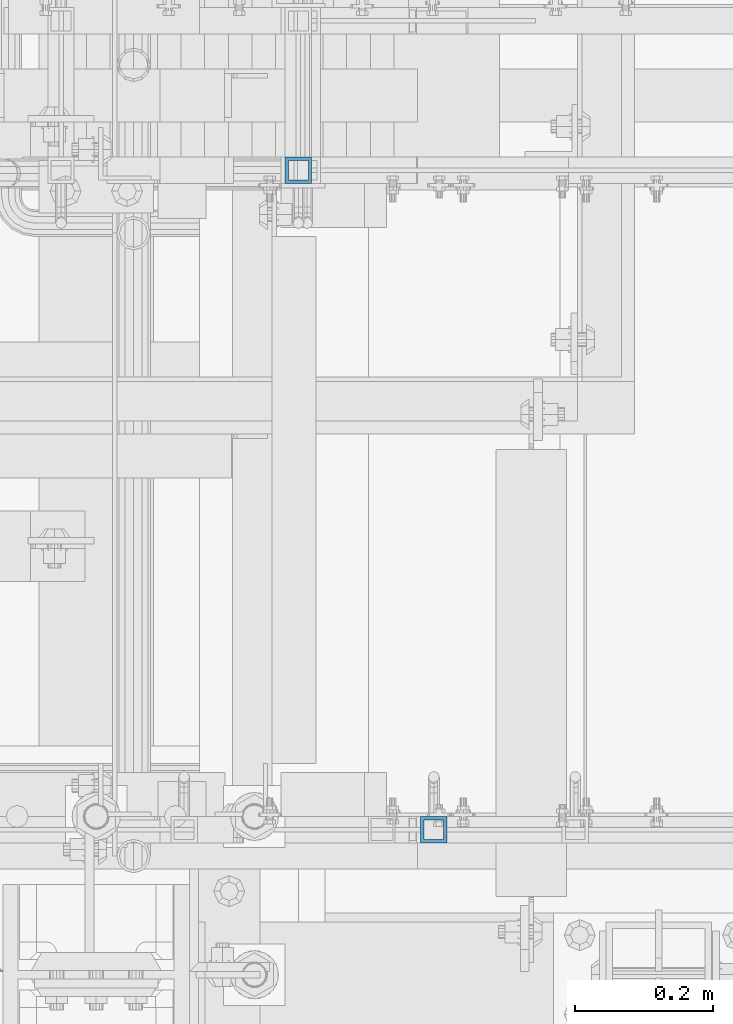
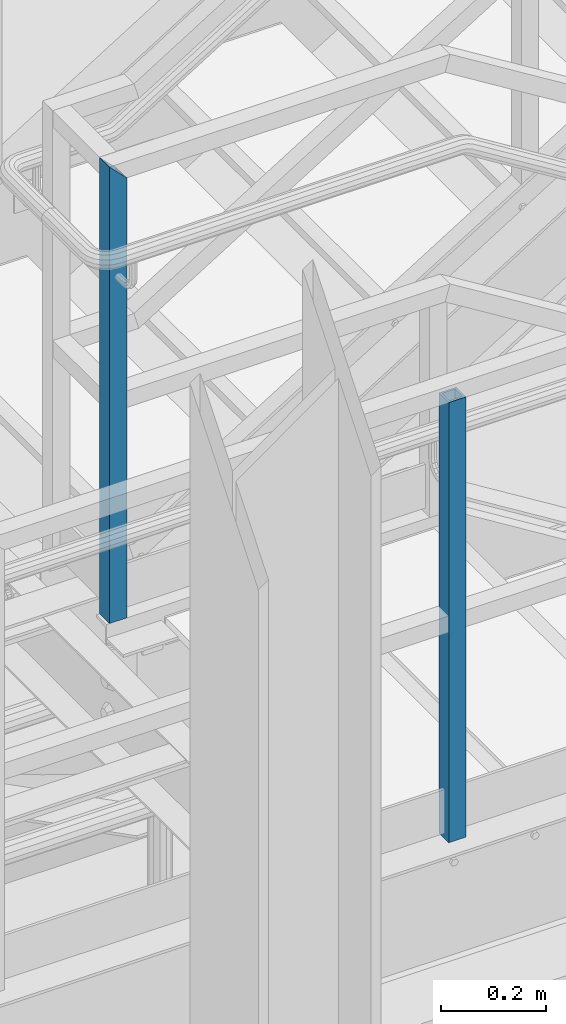
# One storey, part 574 of 1876: 2 columns, 2 elements without a shape of their own.
"""IFC2X3 building model written with IfcOpenShell, lengths in millimetres."""

from ifc_helpers import new_model, si_unit, frame, origin_with_axes, place, context, subcontext, project, spatial, faceted_brep, material, type_object, element, aggregate, save


model = new_model("IFC2X3")

# Units and contexts
model_context = context("Model", 3, precision=1e-05, world=origin_with_axes())
body_context = subcontext(model_context, "Body", "Model", "MODEL_VIEW")
ifc_project = project(units=[si_unit("LENGTHUNIT", "METRE", prefix="MILLI"), si_unit("AREAUNIT", "SQUARE_METRE"), si_unit("VOLUMEUNIT", "CUBIC_METRE"), si_unit("MASSUNIT", "GRAM", prefix="KILO"), si_unit("TIMEUNIT", "SECOND"), si_unit("PLANEANGLEUNIT", "RADIAN"), si_unit("SOLIDANGLEUNIT", "STERADIAN"), si_unit("THERMODYNAMICTEMPERATUREUNIT", "DEGREE_CELSIUS"), si_unit("LUMINOUSINTENSITYUNIT", "LUMEN")], contexts=[model_context])

# Site, building, storey
site_placement = place(None, origin_with_axes())
site = spatial("IfcSite", under=ifc_project, at=site_placement, CompositionType="ELEMENT")
building_placement = place(site_placement, origin_with_axes())
building = spatial("IfcBuilding", under=site, at=building_placement, Name="Undefined", CompositionType="ELEMENT")
storey_placement = place(building_placement, origin_with_axes())
storey = spatial("IfcBuildingStorey", under=building, at=storey_placement, Name="Undefined", CompositionType="ELEMENT", Elevation=0.0)

# Assembly, column
assembly_1_placement = place(storey_placement, origin_with_axes())
assembly_1 = element("IfcElementAssembly", 1, at=assembly_1_placement, inside=storey, Name="RAIL", AssemblyPlace="NOTDEFINED", PredefinedType="RIGID_FRAME")
ifc_material = material()
column_type = type_object("IfcColumnType", Name="HSS1-1/2X1-1/2X3/16", PredefinedType="NOTDEFINED")
column_1_placement = place(assembly_1_placement, frame((2214.88000091923, -6902.45000113495, 15594.7768506203), z_axis=(1.0, 0.0, 0.0), x_axis=(0.0, 0.0, 1.0)))
column_1 = element("IfcColumn", 2, at=column_1_placement, type_object=column_type, material=ifc_material, Name="POST", ObjectType="HSS1-1/2X1-1/2X3/16", context=body_context, shape_type="Brep", body=[
    faceted_brep([(1022.350000765, -19.0499992349996, 19.0499992349996), (1022.35, -19.0499992349996, -19.0499992349996), (1022.35, 19.0499992349996, -19.0499992349996), (1022.350000765, 19.0499992349996, 19.0499992349996), (1022.35, -14.2874994260001, 14.2874994260001), (1022.35, 14.2874994260001, 14.2874994260001), (1022.35, 14.2874994260001, -14.2874994260001), (1022.35, -14.2874994260001, -14.2874994260001), (0.0, 19.0499992349996, 19.0499992349996), (0.0, -19.0499992349996, 19.0499992349996), (0.0, -19.0499992349996, -19.0499992350001), (0.0, 19.0499992349996, -19.0499992350001), (0.0, 14.2874994260001, 14.2874994260001), (0.0, -14.2874994260001, 14.2874994260001), (0.0, -14.2874994260001, -14.2874994260001), (0.0, 14.2874994260001, -14.2874994260001)], [[[0, 1, 2, 3], [4, 5, 6, 7]], [[8, 9, 0, 3]], [[10, 11, 2, 1]], [[9, 10, 1, 0]], [[11, 8, 3, 2]], [[10, 9, 8, 11], [12, 13, 14, 15]], [[14, 13, 4, 7]], [[15, 14, 7, 6]], [[12, 15, 6, 5]], [[13, 12, 5, 4]]]),
])
aggregate(assembly_1, [column_1])

assembly_2_placement = place(storey_placement, origin_with_axes())
assembly_2 = element("IfcElementAssembly", 3, at=assembly_2_placement, inside=storey, Name="RAIL", AssemblyPlace="NOTDEFINED", PredefinedType="RIGID_FRAME")
column_2_placement = place(assembly_2_placement, frame((2019.30000114869, -5949.95000114554, 15594.7768508161), z_axis=(1.0, 0.0, 0.0), x_axis=(0.0, 0.0, 1.0)))
column_2 = element("IfcColumn", 4, at=column_2_placement, type_object=column_type, material=ifc_material, Name="POST", ObjectType="HSS1-1/2X1-1/2X3/16", context=body_context, shape_type="Brep", body=[
    faceted_brep([(0.0, 14.2874994260001, -14.2874994260001), (0.0, -14.2874994260001, -14.2874994260001), (1055.68766311193, -14.2874994260001, -14.2874994260001), (1055.68766311193, 14.2874994260001, -14.2874994260001), (0.0, -14.2874994260001, 14.2874994260001), (1027.11266421952, -14.2874994260001, 14.2874994260001), (0.0, 14.2874994260001, 14.2874994260001), (1027.11266421952, 14.2874994260001, 14.2874994260001), (0.0, 19.0499992349996, -19.0499992350001), (0.0, 19.0499992349996, 19.0499992349996), (1022.35016440378, 19.0499992349996, 19.0499992350001), (1060.45016292766, 19.0499992349996, -19.0499992350001), (0.0, -19.0499992349996, 19.0499992349996), (1022.35016440378, -19.0499992349996, 19.0499992350001), (0.0, -19.0499992349996, -19.0499992350001), (1060.45016292766, -19.0499992349996, -19.0499992350001)], [[[0, 1, 2, 3]], [[1, 4, 5, 2]], [[4, 6, 7, 5]], [[6, 0, 3, 7]], [[8, 9, 10, 11]], [[9, 12, 13, 10]], [[12, 14, 15, 13]], [[14, 8, 11, 15]], [[13, 15, 11, 10], [5, 7, 3, 2]], [[14, 12, 9, 8], [6, 4, 1, 0]]]),
])
aggregate(assembly_2, [column_2])

save(model, "model.ifc")
